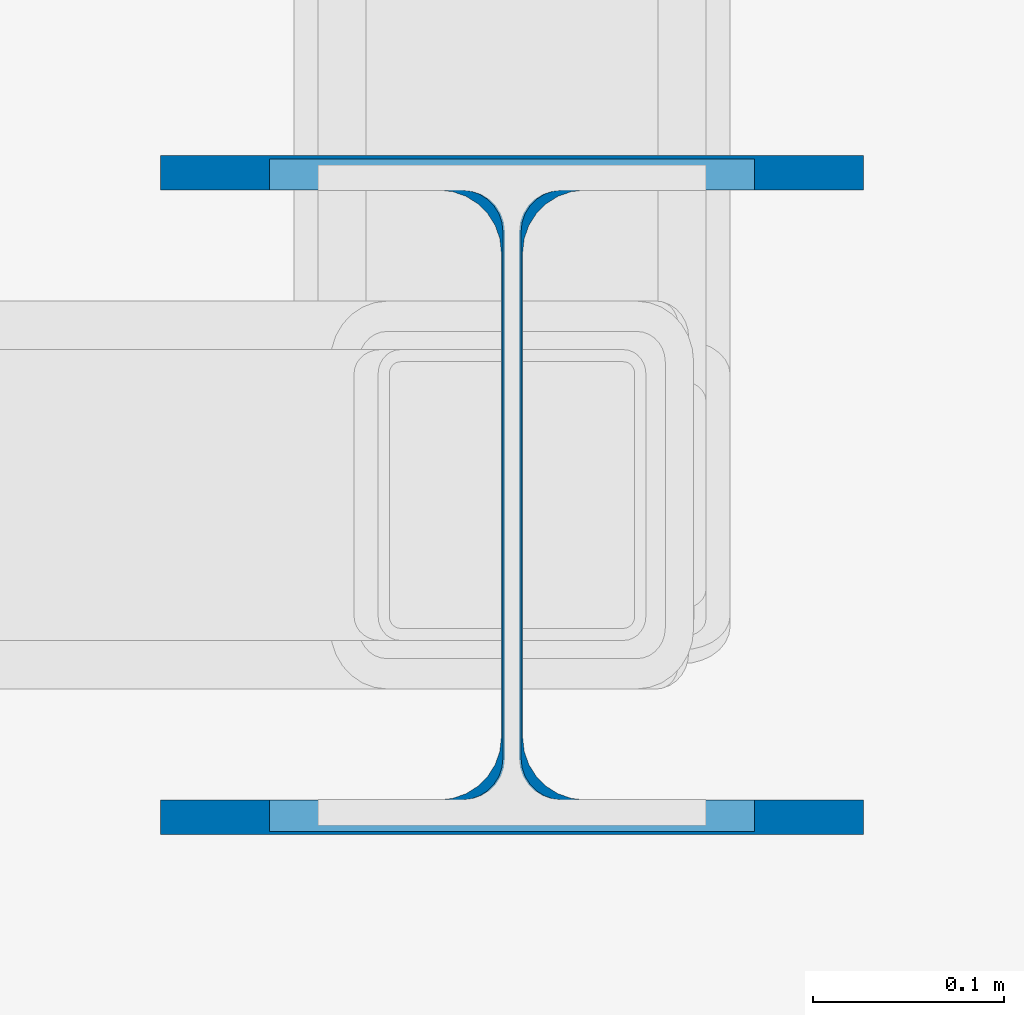
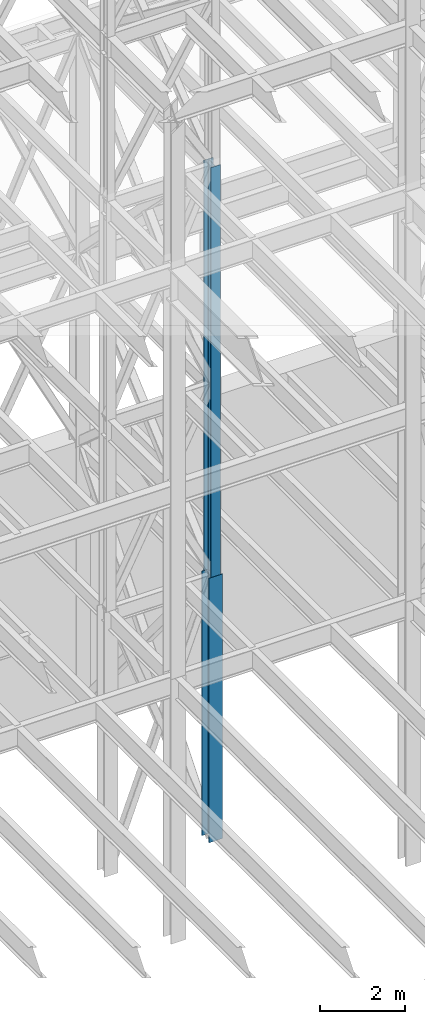
# One storey, part 95 of 150: 2 columns.
"""IFC2X3 building model written with IfcOpenShell, lengths in millimetres."""

from ifc_helpers import new_model, si_unit, frame, origin_with_axes, origin_2d_with_axis, place, context, subcontext, project, spatial, i_section, extrude, material, type_object, element, save


model = new_model("IFC2X3")

# Units and contexts
model_context = context("Model", 3, precision=1e-05, world=origin_with_axes())
body_context = subcontext(model_context, "Body", "Model", "MODEL_VIEW")
ifc_project = project(units=[si_unit("LENGTHUNIT", "METRE", prefix="MILLI"), si_unit("AREAUNIT", "SQUARE_METRE"), si_unit("VOLUMEUNIT", "CUBIC_METRE"), si_unit("MASSUNIT", "GRAM", prefix="KILO"), si_unit("TIMEUNIT", "SECOND"), si_unit("PLANEANGLEUNIT", "RADIAN"), si_unit("SOLIDANGLEUNIT", "STERADIAN"), si_unit("THERMODYNAMICTEMPERATUREUNIT", "DEGREE_CELSIUS"), si_unit("LUMINOUSINTENSITYUNIT", "LUMEN")], contexts=[model_context])

# Site, building, storey
site_placement = place(None, origin_with_axes())
site = spatial("IfcSite", under=ifc_project, at=site_placement, CompositionType="ELEMENT")
building_placement = place(site_placement, origin_with_axes())
building = spatial("IfcBuilding", under=site, at=building_placement, Name="Undefined", CompositionType="ELEMENT")
storey_placement = place(building_placement, origin_with_axes())
storey = spatial("IfcBuildingStorey", under=building, at=storey_placement, Name="Undefined", CompositionType="ELEMENT", Elevation=0.0)

# Columns
ifc_material = material(Name="STEEL/A992")
column_type_1 = type_object("IfcColumnType", Name="W14X61", PredefinedType="NOTDEFINED")
column_1_placement = place(storey_placement, frame((65836.8, 25628.6, 23774.401143), z_axis=(0.0, 0.0, 1.0), x_axis=(1.0, 0.0, 0.0)))
element("IfcColumn", 1, at=column_1_placement, inside=storey, type_object=column_type_1, material=ifc_material, Name="COLUMN", ObjectType="W14X61", context=body_context, shape_type="SweptSolid", body=[
    extrude(i_section(OverallWidth=254.0, OverallDepth=352.425, WebThickness=9.5249, FlangeThickness=16.383, FilletRadius=21.717, at=origin_2d_with_axis()), frame((0.0, 0.0, 11811.0), z_axis=(0.0, 0.0, -1.0), x_axis=(-1.0, 0.0, 0.0)), (0.0, 0.0, 1.0), 11811.0),
])
column_type_2 = type_object("IfcColumnType", Name="W14X90", PredefinedType="NOTDEFINED")
column_2_placement = place(storey_placement, frame((65836.8, 25628.6, 16154.401143), z_axis=(0.0, 0.0, 1.0), x_axis=(1.0, 0.0, 0.0)))
element("IfcColumn", 2, at=column_2_placement, inside=storey, type_object=column_type_2, material=ifc_material, Name="COLUMN", ObjectType="W14X90", context=body_context, shape_type="SweptSolid", body=[
    extrude(i_section(OverallWidth=368.3, OverallDepth=355.6, WebThickness=11.1125, FlangeThickness=18.034, FilletRadius=32.7659, at=origin_2d_with_axis()), frame((0.0, 0.0, 7620.0), z_axis=(0.0, 0.0, -1.0), x_axis=(-1.0, 0.0, 0.0)), (0.0, 0.0, 1.0), 7620.0),
])

save(model, "model.ifc")
